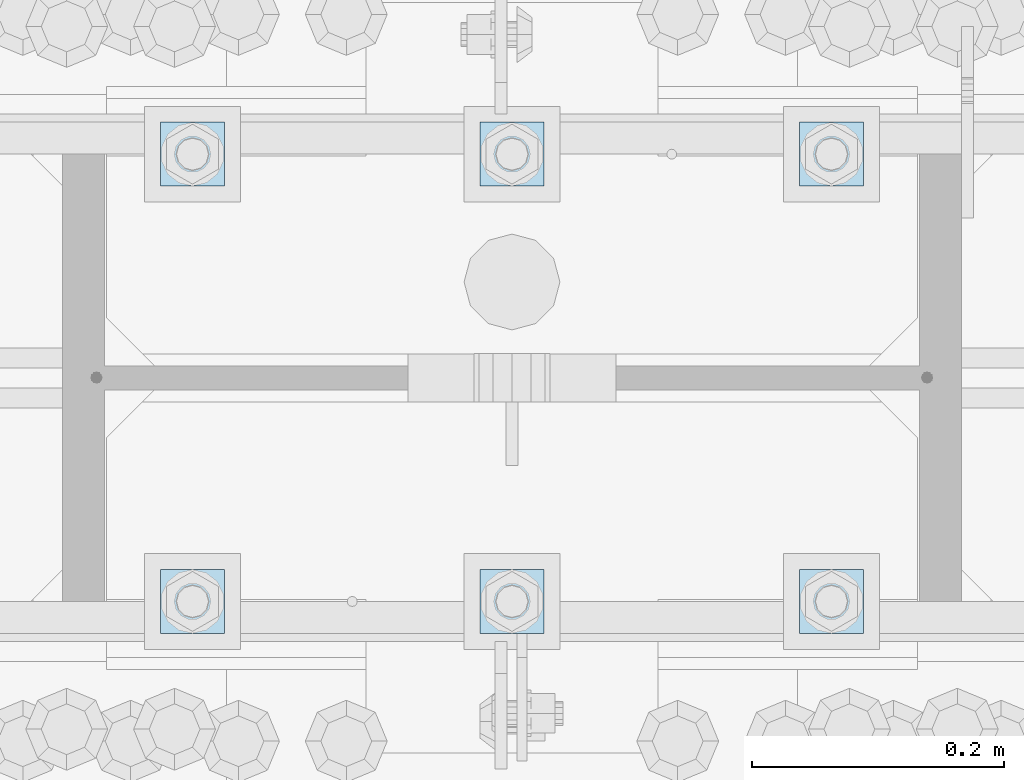
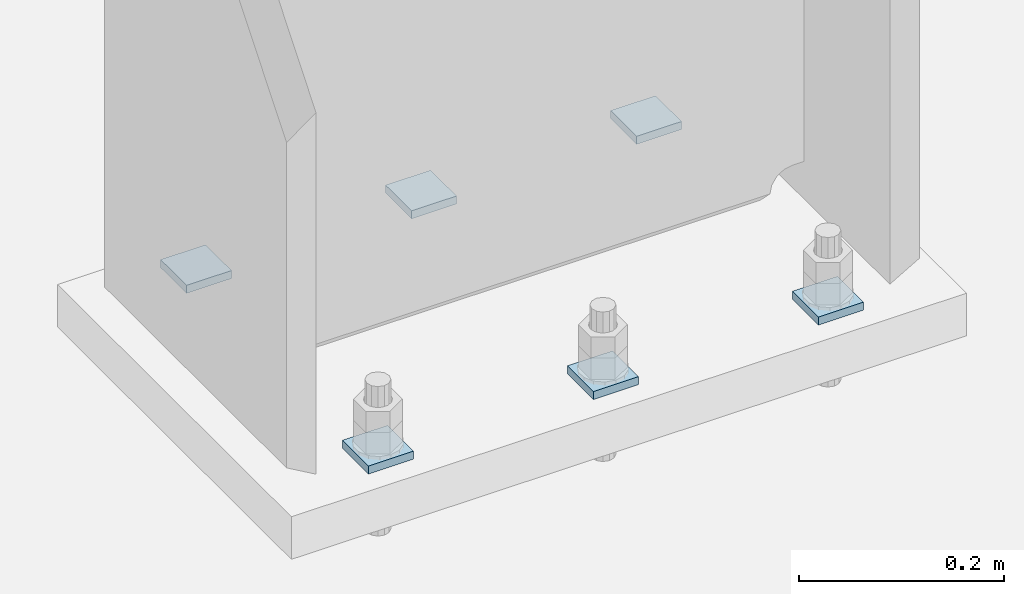
# One storey, part 1711 of 1763: 6 plates, 1 element without a shape of its own.
"""IFC2X3 building model written with IfcOpenShell, lengths in millimetres."""

from ifc_helpers import new_model, si_unit, frame, origin_with_axes, place, context, subcontext, project, spatial, faceted_brep, material, type_object, element, aggregate, save


model = new_model("IFC2X3")

# Units and contexts
model_context = context("Model", 3, precision=1e-05, world=origin_with_axes())
body_context = subcontext(model_context, "Body", "Model", "MODEL_VIEW")
ifc_project = project(units=[si_unit("LENGTHUNIT", "METRE", prefix="MILLI"), si_unit("AREAUNIT", "SQUARE_METRE"), si_unit("VOLUMEUNIT", "CUBIC_METRE"), si_unit("MASSUNIT", "GRAM", prefix="KILO"), si_unit("TIMEUNIT", "SECOND"), si_unit("PLANEANGLEUNIT", "RADIAN"), si_unit("SOLIDANGLEUNIT", "STERADIAN"), si_unit("THERMODYNAMICTEMPERATUREUNIT", "DEGREE_CELSIUS"), si_unit("LUMINOUSINTENSITYUNIT", "LUMEN")], contexts=[model_context])

# Site, building, storey
site_placement = place(None, origin_with_axes())
site = spatial("IfcSite", under=ifc_project, at=site_placement, CompositionType="ELEMENT")
building_placement = place(site_placement, origin_with_axes())
building = spatial("IfcBuilding", under=site, at=building_placement, Name="Undefined", CompositionType="ELEMENT")
storey_placement = place(building_placement, origin_with_axes())
storey = spatial("IfcBuildingStorey", under=building, at=storey_placement, Name="Undefined", CompositionType="ELEMENT", Elevation=0.0)

# Assembly, plates
assembly_placement = place(storey_placement, origin_with_axes())
assembly = element("IfcElementAssembly", 1, at=assembly_placement, inside=storey, Name="TEMPLATE", AssemblyPlace="NOTDEFINED", PredefinedType="RIGID_FRAME")
ifc_material = material(Name="STEEL/A36")
plate_type = type_object("IfcPlateType", PredefinedType="NOTDEFINED")
plate_1_placement = place(assembly_placement, frame((-61365.8372736984, 51968.4, -211.137499999996), z_axis=(0.0, -1.0, 0.0), x_axis=(1.0, 0.0, 0.0)))
plate_1 = element("IfcPlate", 2, at=plate_1_placement, type_object=plate_type, material=ifc_material, Name="Washer Plate", context=body_context, shape_type="Brep", body=[
    faceted_brep([(0.0, -4.76249999999982, 0.0), (0.0, -4.76249999999999, 50.7999992370605), (0.0, 4.76249999999999, 50.7999992370605), (0.0, 4.76249999999982, 0.0), (50.7999992370605, -4.76249999999999, 50.7999992370605), (50.7999992370605, 4.76249999999999, 50.7999992370605), (50.7999992370605, -4.76249999999709, 0.0), (50.7999992370605, 4.76249999999709, 0.0)], [[[0, 1, 2, 3]], [[1, 4, 5, 2]], [[4, 6, 7, 5]], [[6, 0, 3, 7]], [[5, 7, 3, 2]], [[6, 4, 1, 0]]]),
])
plate_2_placement = place(assembly_placement, frame((-61365.8372736984, 52324.0, -211.137499999996), z_axis=(0.0, -1.0, 0.0), x_axis=(1.0, 0.0, 0.0)))
plate_2 = element("IfcPlate", 3, at=plate_2_placement, type_object=plate_type, material=ifc_material, Name="Washer Plate", context=body_context, shape_type="Brep", body=[
    faceted_brep([(0.0, -4.76249999999982, 0.0), (0.0, -4.76249999999999, 50.7999992370605), (0.0, 4.76249999999999, 50.7999992370605), (0.0, 4.76249999999982, 0.0), (50.7999992370605, -4.76249999999999, 50.7999992370605), (50.7999992370605, 4.76249999999999, 50.7999992370605), (50.7999992370605, -4.76249999999709, 0.0), (50.7999992370605, 4.76249999999709, 0.0)], [[[0, 1, 2, 3]], [[1, 4, 5, 2]], [[4, 6, 7, 5]], [[6, 0, 3, 7]], [[5, 7, 3, 2]], [[6, 4, 1, 0]]]),
])
plate_3_placement = place(assembly_placement, frame((-61619.8372736984, 51968.4, -211.137499999996), z_axis=(0.0, -1.0, 0.0), x_axis=(1.0, 0.0, 0.0)))
plate_3 = element("IfcPlate", 4, at=plate_3_placement, type_object=plate_type, material=ifc_material, Name="Washer Plate", context=body_context, shape_type="Brep", body=[
    faceted_brep([(0.0, -4.76249999999982, 0.0), (0.0, -4.76249999999999, 50.7999992370605), (0.0, 4.76249999999999, 50.7999992370605), (0.0, 4.76249999999982, 0.0), (50.7999992370605, -4.76249999999999, 50.7999992370605), (50.7999992370605, 4.76249999999999, 50.7999992370605), (50.7999992370605, -4.76249999999709, 0.0), (50.7999992370605, 4.76249999999709, 0.0)], [[[0, 1, 2, 3]], [[1, 4, 5, 2]], [[4, 6, 7, 5]], [[6, 0, 3, 7]], [[5, 7, 3, 2]], [[6, 4, 1, 0]]]),
])
plate_4_placement = place(assembly_placement, frame((-61619.8372736984, 52324.0, -211.137499999996), z_axis=(0.0, -1.0, 0.0), x_axis=(1.0, 0.0, 0.0)))
plate_4 = element("IfcPlate", 5, at=plate_4_placement, type_object=plate_type, material=ifc_material, Name="Washer Plate", context=body_context, shape_type="Brep", body=[
    faceted_brep([(0.0, -4.76249999999982, 0.0), (0.0, -4.76249999999999, 50.7999992370605), (0.0, 4.76249999999999, 50.7999992370605), (0.0, 4.76249999999982, 0.0), (50.7999992370605, -4.76249999999999, 50.7999992370605), (50.7999992370605, 4.76249999999999, 50.7999992370605), (50.7999992370605, -4.76249999999709, 0.0), (50.7999992370605, 4.76249999999709, 0.0)], [[[0, 1, 2, 3]], [[1, 4, 5, 2]], [[4, 6, 7, 5]], [[6, 0, 3, 7]], [[5, 7, 3, 2]], [[6, 4, 1, 0]]]),
])
plate_5_placement = place(assembly_placement, frame((-61873.8372736984, 51968.4, -211.137499999996), z_axis=(0.0, -1.0, 0.0), x_axis=(1.0, 0.0, 0.0)))
plate_5 = element("IfcPlate", 6, at=plate_5_placement, type_object=plate_type, material=ifc_material, Name="Washer Plate", context=body_context, shape_type="Brep", body=[
    faceted_brep([(0.0, -4.76249999999982, 0.0), (0.0, -4.76249999999999, 50.7999992370605), (0.0, 4.76249999999999, 50.7999992370605), (0.0, 4.76249999999982, 0.0), (50.7999992370605, -4.76249999999999, 50.7999992370605), (50.7999992370605, 4.76249999999999, 50.7999992370605), (50.7999992370605, -4.76249999999709, 0.0), (50.7999992370605, 4.76249999999709, 0.0)], [[[0, 1, 2, 3]], [[1, 4, 5, 2]], [[4, 6, 7, 5]], [[6, 0, 3, 7]], [[5, 7, 3, 2]], [[6, 4, 1, 0]]]),
])
plate_6_placement = place(assembly_placement, frame((-61873.8372736984, 52324.0, -211.137499999996), z_axis=(0.0, -1.0, 0.0), x_axis=(1.0, 0.0, 0.0)))
plate_6 = element("IfcPlate", 7, at=plate_6_placement, type_object=plate_type, material=ifc_material, Name="Washer Plate", context=body_context, shape_type="Brep", body=[
    faceted_brep([(0.0, -4.76249999999982, 0.0), (0.0, -4.76249999999999, 50.7999992370605), (0.0, 4.76249999999999, 50.7999992370605), (0.0, 4.76249999999982, 0.0), (50.7999992370605, -4.76249999999999, 50.7999992370605), (50.7999992370605, 4.76249999999999, 50.7999992370605), (50.7999992370605, -4.76249999999709, 0.0), (50.7999992370605, 4.76249999999709, 0.0)], [[[0, 1, 2, 3]], [[1, 4, 5, 2]], [[4, 6, 7, 5]], [[6, 0, 3, 7]], [[5, 7, 3, 2]], [[6, 4, 1, 0]]]),
])
aggregate(assembly, [plate_1, plate_2, plate_3, plate_4, plate_5, plate_6])

save(model, "model.ifc")
